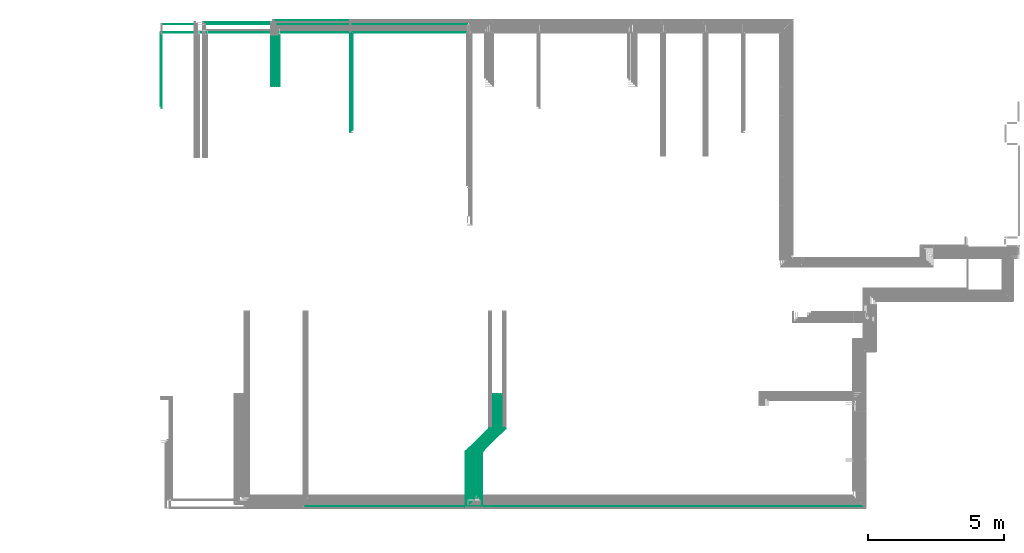
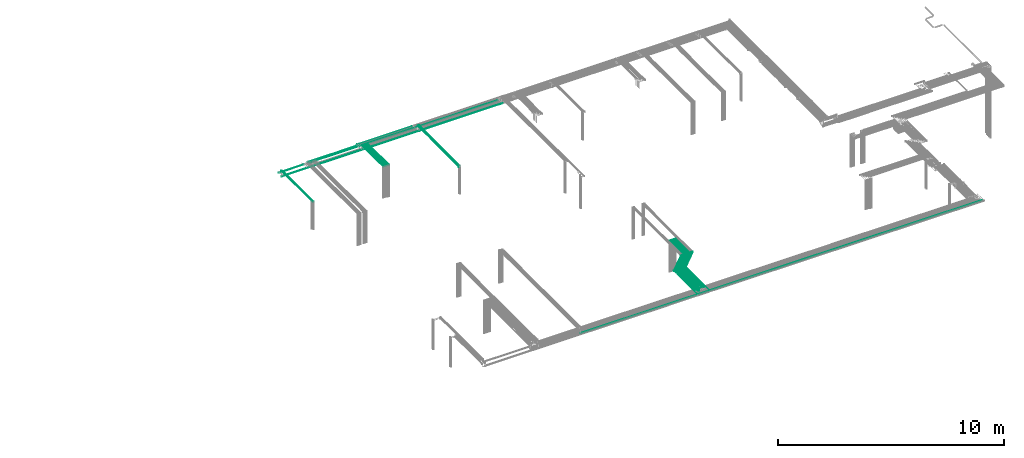
# One storey, part 11 of 89: 40 flow segments.
"""IFC2X3 building model written with IfcOpenShell, lengths in millimetres."""

from ifc_helpers import new_model, entity, si_unit, converted_unit, derived_unit, direction, frame, frame_2d, origin, origin_2d_with_axis, place, context, subcontext, project, spatial, circle, extrude, type_object, element, save


model = new_model("IFC2X3")

# Units and contexts
model_context = context("Model", 3, precision=0.01, world=origin(), true_north=direction((6.12303176911189e-17, 1.0)))
body_context = subcontext(model_context, "Body", "Model", "MODEL_VIEW")
ifc_project = project(units=[si_unit("LENGTHUNIT", "METRE", prefix="MILLI"), si_unit("AREAUNIT", "SQUARE_METRE"), si_unit("VOLUMEUNIT", "CUBIC_METRE"), converted_unit("PLANEANGLEUNIT", "DEGREE", entity("IfcRatioMeasure", 0.0174532925199433), si_unit("PLANEANGLEUNIT", "RADIAN"), dimensions=[0, 0, 0, 0, 0, 0, 0]), si_unit("MASSUNIT", "GRAM", prefix="KILO"), derived_unit("MASSDENSITYUNIT", [(si_unit("MASSUNIT", "GRAM", prefix="KILO"), 1), (si_unit("LENGTHUNIT", "METRE"), -3)]), derived_unit("MOMENTOFINERTIAUNIT", [(si_unit("LENGTHUNIT", "METRE"), 4)]), si_unit("TIMEUNIT", "SECOND"), si_unit("FREQUENCYUNIT", "HERTZ"), si_unit("THERMODYNAMICTEMPERATUREUNIT", "DEGREE_CELSIUS"), derived_unit("THERMALTRANSMITTANCEUNIT", [(si_unit("MASSUNIT", "GRAM", prefix="KILO"), 1), (si_unit("THERMODYNAMICTEMPERATUREUNIT", "KELVIN"), -1), (si_unit("TIMEUNIT", "SECOND"), -3)]), derived_unit("VOLUMETRICFLOWRATEUNIT", [(si_unit("LENGTHUNIT", "METRE"), 3), (si_unit("TIMEUNIT", "SECOND"), -1)]), derived_unit("MASSFLOWRATEUNIT", [(si_unit("MASSUNIT", "GRAM", prefix="KILO"), 1), (si_unit("TIMEUNIT", "SECOND"), -1)]), derived_unit("ROTATIONALFREQUENCYUNIT", [(si_unit("TIMEUNIT", "SECOND"), -1)]), si_unit("ELECTRICCURRENTUNIT", "AMPERE"), si_unit("ELECTRICVOLTAGEUNIT", "VOLT"), si_unit("POWERUNIT", "WATT"), si_unit("FORCEUNIT", "NEWTON", prefix="KILO"), si_unit("ILLUMINANCEUNIT", "LUX"), si_unit("LUMINOUSFLUXUNIT", "LUMEN"), si_unit("LUMINOUSINTENSITYUNIT", "CANDELA"), derived_unit("USERDEFINED", [(si_unit("MASSUNIT", "GRAM", prefix="KILO"), -1), (si_unit("LENGTHUNIT", "METRE"), -2), (si_unit("TIMEUNIT", "SECOND"), 3), (si_unit("LUMINOUSFLUXUNIT", "LUMEN"), 1)]), derived_unit("LINEARVELOCITYUNIT", [(si_unit("LENGTHUNIT", "METRE"), 1), (si_unit("TIMEUNIT", "SECOND"), -1)]), si_unit("PRESSUREUNIT", "PASCAL"), derived_unit("USERDEFINED", [(si_unit("LENGTHUNIT", "METRE"), -2), (si_unit("MASSUNIT", "GRAM", prefix="KILO"), 1), (si_unit("TIMEUNIT", "SECOND"), -2)]), derived_unit("LINEARFORCEUNIT", [(si_unit("MASSUNIT", "GRAM", prefix="KILO"), 1), (si_unit("LENGTHUNIT", "METRE"), 1), (si_unit("TIMEUNIT", "SECOND"), -2), (si_unit("LENGTHUNIT", "METRE"), -1)]), derived_unit("PLANARFORCEUNIT", [(si_unit("MASSUNIT", "GRAM", prefix="KILO"), 1), (si_unit("LENGTHUNIT", "METRE"), 1), (si_unit("TIMEUNIT", "SECOND"), -2), (si_unit("LENGTHUNIT", "METRE"), -2)])], contexts=[model_context])

# Site, building, storey
site_placement = place(None, frame((0.0, -0.00077364408347762, 0.0)))
site = spatial("IfcSite", under=ifc_project, at=site_placement, CompositionType="ELEMENT")
building_placement = place(site_placement, origin())
building = spatial("IfcBuilding", under=site, at=building_placement, CompositionType="ELEMENT")
storey_placement = place(building_placement, frame((0.0, 0.0, 24000.0)))
storey = spatial("IfcBuildingStorey", under=building, at=storey_placement, CompositionType="ELEMENT", Elevation=24000.0)

# Flow segments
pipe_segment_type = type_object("IfcPipeSegmentType", PredefinedType="NOTDEFINED")
flow_segment_1_placement = place(storey_placement, frame((53135.5981151137, 1334.95129953586, 3069.40472776409)))
element("IfcFlowSegment", 1, at=flow_segment_1_placement, inside=storey, type_object=pipe_segment_type, context=body_context, shape_type="SweptSolid", body=[
    extrude(circle(Radius=4.0, at=origin_2d_with_axis()), frame((5.59527223591499, 0.0, 5.59527223591499), z_axis=(0.0, 1.0, 0.0), x_axis=(1.0, 0.0, 0.0)), (0.0, 0.0, 1.0), 1914.32054256963),
])
flow_segment_2_placement = place(storey_placement, frame((53211.0054086232, 1409.95129953583, 3069.40472776409)))
element("IfcFlowSegment", 2, at=flow_segment_2_placement, inside=storey, type_object=pipe_segment_type, context=body_context, shape_type="SweptSolid", body=[
    extrude(circle(Radius=4.0, at=origin_2d_with_axis()), frame((5.59527223590633, 0.0, 5.59527223591499), z_axis=(0.0, 1.0, 0.0), x_axis=(1.0, 0.0, 0.0)), (0.0, 0.0, 1.0), 1839.32054256966),
])
flow_segment_3_placement = place(storey_placement, frame((53285.5981151137, 1484.95129953586, 3069.40472776409)))
element("IfcFlowSegment", 3, at=flow_segment_3_placement, inside=storey, type_object=pipe_segment_type, context=body_context, shape_type="SweptSolid", body=[
    extrude(circle(Radius=4.0, at=origin_2d_with_axis()), frame((5.59527223591499, 0.0, 5.59527223591499), z_axis=(0.0, 1.0, 0.0), x_axis=(1.0, 0.0, 0.0)), (0.0, 0.0, 1.0), 1764.32054256963),
])
flow_segment_4_placement = place(storey_placement, frame((53360.5981151137, 1634.95129953587, 3069.40472776409)))
element("IfcFlowSegment", 4, at=flow_segment_4_placement, inside=storey, type_object=pipe_segment_type, context=body_context, shape_type="SweptSolid", body=[
    extrude(circle(Radius=4.0, at=origin_2d_with_axis()), frame((5.59527223591499, 0.0, 5.59527223591499), z_axis=(0.0, 1.0, 0.0), x_axis=(1.0, 0.0, 0.0)), (0.0, 0.0, 1.0), 1614.32054256962),
])
flow_segment_5_placement = place(storey_placement, frame((53435.5981151137, 1559.95129953584, 3069.40472776409)))
element("IfcFlowSegment", 5, at=flow_segment_5_placement, inside=storey, type_object=pipe_segment_type, context=body_context, shape_type="SweptSolid", body=[
    extrude(circle(Radius=4.0, at=origin_2d_with_axis()), frame((5.59527223590633, 0.0, 5.59527223591499), z_axis=(0.0, 1.0, 0.0), x_axis=(1.0, 0.0, 0.0)), (0.0, 0.0, 1.0), 1689.32054256965),
])
flow_segment_6_placement = place(storey_placement, frame((53510.5981151137, 1484.95129953586, 3069.40472776409)))
element("IfcFlowSegment", 6, at=flow_segment_6_placement, inside=storey, type_object=pipe_segment_type, context=body_context, shape_type="SweptSolid", body=[
    extrude(circle(Radius=4.0, at=origin_2d_with_axis()), frame((5.59527223591499, 0.0, 5.59527223591499), z_axis=(0.0, 1.0, 0.0), x_axis=(1.0, 0.0, 0.0)), (0.0, 0.0, 1.0), 1764.32054256963),
])
flow_segment_7_placement = place(storey_placement, frame((53585.5981151137, 1184.95129953582, 3069.40472776409)))
element("IfcFlowSegment", 7, at=flow_segment_7_placement, inside=storey, type_object=pipe_segment_type, context=body_context, shape_type="SweptSolid", body=[
    extrude(circle(Radius=4.0, at=origin_2d_with_axis()), frame((5.59527223591499, 0.0, 5.59527223591499), z_axis=(0.0, 1.0, 0.0), x_axis=(1.0, 0.0, 0.0)), (0.0, 0.0, 1.0), 2064.32054256967),
])
flow_segment_8_placement = place(storey_placement, frame((53060.5981151137, 1484.95129953586, 3069.40472776409)))
element("IfcFlowSegment", 8, at=flow_segment_8_placement, inside=storey, type_object=pipe_segment_type, context=body_context, shape_type="SweptSolid", body=[
    extrude(circle(Radius=4.0, at=origin_2d_with_axis()), frame((5.59527223590633, 0.0, 5.59527223591499), z_axis=(0.0, 1.0, 0.0), x_axis=(1.0, 0.0, 0.0)), (0.0, 0.0, 1.0), 1764.32054256963),
])
flow_segment_9_placement = place(storey_placement, frame((52985.5981151137, 1184.95129953582, 3069.40472776409)))
element("IfcFlowSegment", 9, at=flow_segment_9_placement, inside=storey, type_object=pipe_segment_type, context=body_context, shape_type="SweptSolid", body=[
    extrude(circle(Radius=4.0, at=frame_2d((1.10044925673919e-39, 3.0320279620355e-11), x_axis=(1.0, 0.0))), frame((5.59527223591499, 0.0, 5.59527223594531), z_axis=(0.0, 1.0, 0.0), x_axis=(-1.0, 0.0, 0.0)), (0.0, 0.0, 1.0), 2065.83581081374),
])
flow_segment_10_placement = place(storey_placement, frame((47031.1935200703, 1244.3560272999, 2994.40472776409)))
element("IfcFlowSegment", 10, at=flow_segment_10_placement, inside=storey, type_object=pipe_segment_type, context=body_context, shape_type="SweptSolid", body=[
    extrude(circle(Radius=4.0, at=frame_2d((-1.89501747627219e-12, 0.0), x_axis=(1.0, 0.0))), frame((0.0, 5.5952722359177, 5.59527223591499), z_axis=(1.0, 0.0, 0.0), x_axis=(0.0, 1.0, 0.0)), (0.0, 0.0, 1.0), 20553.8067484846),
])
for number, where in (
    (11, (53985.5981151137, 4107.27184210549, 3069.40472776409)),
    (12, (54061.0054086232, 4107.27184210549, 3069.40472776409)),
    (13, (54135.5981151137, 4107.27184210549, 3069.40472776409)),
):
    element("IfcFlowSegment", number, at=place(storey_placement, frame(where)), inside=storey, type_object=pipe_segment_type, context=body_context, shape_type="SweptSolid", body=[
        extrude(circle(Radius=4.0, at=origin_2d_with_axis()), frame((5.59527223591499, 0.0, 5.59527223591499), z_axis=(0.0, 1.0, 0.0), x_axis=(-1.0, 0.0, 0.0)), (0.0, 0.0, 1.0), 1252.73249573645),
    ])
flow_segment_11_placement = place(storey_placement, frame((54210.5981151137, 4107.27184210549, 3069.40472776409)))
element("IfcFlowSegment", 14, at=flow_segment_11_placement, inside=storey, type_object=pipe_segment_type, context=body_context, shape_type="SweptSolid", body=[
    extrude(circle(Radius=4.0, at=frame_2d((8.66293703438714e-12, 0.0), x_axis=(1.0, 0.0))), frame((5.59527223592365, 0.0, 5.59527223591499), z_axis=(0.0, 1.0, 0.0), x_axis=(-1.0, 0.0, 0.0)), (0.0, 0.0, 1.0), 1252.73249573645),
])
flow_segment_12_placement = place(storey_placement, frame((54285.5981151137, 4107.27184210549, 3069.40472776409)))
element("IfcFlowSegment", 15, at=flow_segment_12_placement, inside=storey, type_object=pipe_segment_type, context=body_context, shape_type="SweptSolid", body=[
    extrude(circle(Radius=4.0, at=origin_2d_with_axis()), frame((5.59527223591499, 0.0, 5.59527223591499), z_axis=(0.0, 1.0, 0.0), x_axis=(-1.0, 0.0, 0.0)), (0.0, 0.0, 1.0), 1252.73249573645),
])
flow_segment_13_placement = place(storey_placement, frame((52989.5981151137, 3253.19183811364, 3069.40472776409)))
element("IfcFlowSegment", 16, at=flow_segment_13_placement, inside=storey, type_object=pipe_segment_type, context=body_context, shape_type="SweptSolid", body=[
    extrude(circle(Radius=4.0, at=origin_2d_with_axis()), frame((4.42369936066011, 4.42369936066065, 5.59527223591499), z_axis=(0.707106781186546, 0.707106781186549, 0.0), x_axis=(-0.707106781186549, 0.707106781186546, 0.0)), (0.0, 0.0, 1.0), 1194.08152801714),
])
flow_segment_14_placement = place(storey_placement, frame((53064.5981151137, 3251.67656986958, 3069.40472776409)))
element("IfcFlowSegment", 17, at=flow_segment_14_placement, inside=storey, type_object=pipe_segment_type, context=body_context, shape_type="SweptSolid", body=[
    extrude(circle(Radius=4.0, at=origin_2d_with_axis()), frame((4.42369936065145, 4.42369936066065, 5.59527223591499), z_axis=(0.707106781186546, 0.707106781186549, 0.0), x_axis=(-0.707106781186549, 0.707106781186546, 0.0)), (0.0, 0.0, 1.0), 1194.08152801713),
])
for number, where in (
    (18, (53139.5981151137, 3251.67656986958, 3069.40472776409)),
    (19, (53215.0054086232, 3251.67656986958, 3069.40472776409)),
    (20, (53289.5981151137, 3251.67656986958, 3069.40472776409)),
):
    element("IfcFlowSegment", number, at=place(storey_placement, frame(where)), inside=storey, type_object=pipe_segment_type, context=body_context, shape_type="SweptSolid", body=[
        extrude(circle(Radius=4.0, at=origin_2d_with_axis()), frame((4.42369936065145, 4.4236993606612, 5.59527223591499), z_axis=(0.707106781186545, 0.70710678118655, 0.0), x_axis=(-0.70710678118655, 0.707106781186545, 0.0)), (0.0, 0.0, 1.0), 1194.08152801713),
    ])
flow_segment_15_placement = place(storey_placement, frame((53364.5981151137, 3251.67656986958, 3069.40472776409)))
element("IfcFlowSegment", 21, at=flow_segment_15_placement, inside=storey, type_object=pipe_segment_type, context=body_context, shape_type="SweptSolid", body=[
    extrude(circle(Radius=4.0, at=origin_2d_with_axis()), frame((4.42369936065145, 4.42369936066065, 5.59527223591499), z_axis=(0.707106781186546, 0.707106781186549, 0.0), x_axis=(-0.707106781186549, 0.707106781186546, 0.0)), (0.0, 0.0, 1.0), 1194.08152801713),
])
flow_segment_16_placement = place(storey_placement, frame((53439.5981151137, 3251.67656986958, 3069.40472776409)))
element("IfcFlowSegment", 22, at=flow_segment_16_placement, inside=storey, type_object=pipe_segment_type, context=body_context, shape_type="SweptSolid", body=[
    extrude(circle(Radius=4.0, at=origin_2d_with_axis()), frame((4.42369936065145, 4.4236993606612, 5.59527223591499), z_axis=(0.707106781186545, 0.70710678118655, 0.0), x_axis=(-0.70710678118655, 0.707106781186545, 0.0)), (0.0, 0.0, 1.0), 1194.08152801713),
])
for number, where in (
    (23, (53514.5981151137, 3251.67656986958, 3069.40472776409)),
    (24, (53589.5981151137, 3251.67656986958, 3069.40472776409)),
):
    element("IfcFlowSegment", number, at=place(storey_placement, frame(where)), inside=storey, type_object=pipe_segment_type, context=body_context, shape_type="SweptSolid", body=[
        extrude(circle(Radius=4.0, at=origin_2d_with_axis()), frame((4.42369936066011, 4.4236993606612, 5.59527223591499), z_axis=(0.707106781186545, 0.70710678118655, 0.0), x_axis=(-0.70710678118655, 0.707106781186545, 0.0)), (0.0, 0.0, 1.0), 1194.08152801713),
    ])
flow_segment_17_placement = place(storey_placement, frame((41771.3043091155, 15945.0, 3069.4047277641)))
element("IfcFlowSegment", 25, at=flow_segment_17_placement, inside=storey, type_object=pipe_segment_type, context=body_context, shape_type="SweptSolid", body=[
    extrude(circle(Radius=4.0, at=frame_2d((-8.66293703438714e-12, 0.0), x_axis=(1.0, 0.0))), frame((5.59527223591499, 0.0, 5.59527223591499), z_axis=(0.0, 1.0, 0.0), x_axis=(-1.0, 0.0, 0.0)), (0.0, 0.0, 1.0), 2695.00000730896),
])
flow_segment_18_placement = place(storey_placement, frame((41814.4237854135, 15870.0, 3069.4047277641)))
element("IfcFlowSegment", 26, at=flow_segment_18_placement, inside=storey, type_object=pipe_segment_type, context=body_context, shape_type="SweptSolid", body=[
    extrude(circle(Radius=4.0, at=origin_2d_with_axis()), frame((5.59527223590633, 0.0, 5.59527223591499), z_axis=(0.0, 1.0, 0.0), x_axis=(1.0, 0.0, 0.0)), (0.0, 0.0, 1.0), 2700.00000000001),
])
flow_segment_19_placement = place(storey_placement, frame((43415.3360917165, 18944.4047277641, 2769.4047277641)))
element("IfcFlowSegment", 27, at=flow_segment_19_placement, inside=storey, type_object=pipe_segment_type, context=body_context, shape_type="SweptSolid", body=[
    extrude(circle(Radius=4.0, at=origin_2d_with_axis()), frame((0.0, 5.59527223593232, 5.59527223591499), z_axis=(1.0, 0.0, 0.0), x_axis=(0.0, -1.0, 0.0)), (0.0, 0.0, 1.0), 2574.38010976152),
])
flow_segment_20_placement = place(storey_placement, frame((45914.1209292421, 16667.0, 3069.4047277641)))
element("IfcFlowSegment", 28, at=flow_segment_20_placement, inside=storey, type_object=pipe_segment_type, context=body_context, shape_type="SweptSolid", body=[
    extrude(circle(Radius=4.0, at=origin_2d_with_axis()), frame((5.59527223591499, 0.0, 5.59527223591499), z_axis=(0.0, 1.0, 0.0), x_axis=(1.0, 0.0, 0.0)), (0.0, 0.0, 1.0), 1880.00000000001),
])
flow_segment_21_placement = place(storey_placement, frame((45929.716201478, 19094.4047277642, 2769.4047277641)))
element("IfcFlowSegment", 29, at=flow_segment_21_placement, inside=storey, type_object=pipe_segment_type, context=body_context, shape_type="SweptSolid", body=[
    extrude(circle(Radius=4.0, at=frame_2d((2.16573425859679e-12, 0.0), x_axis=(1.0, 0.0))), frame((0.0, 5.59527223591499, 5.59527223591499), z_axis=(1.0, 0.0, 0.0), x_axis=(0.0, 1.0, 0.0)), (0.0, 0.0, 1.0), 2811.65681787896),
])
for number, where in (
    (30, (45839.1209292422, 16667.0, 3069.40472776409)),
    (31, (45989.1209292421, 16667.0, 3069.40472776409)),
    (32, (46064.1209292421, 16667.0, 3069.40472776409)),
    (33, (46139.1209292421, 16667.0, 3069.40472776409)),
):
    element("IfcFlowSegment", number, at=place(storey_placement, frame(where)), inside=storey, type_object=pipe_segment_type, context=body_context, shape_type="SweptSolid", body=[
        extrude(circle(Radius=4.0, at=origin_2d_with_axis()), frame((5.59527223591499, 0.0, 5.59527223591499), z_axis=(0.0, 1.0, 0.0), x_axis=(1.0, 0.0, 0.0)), (0.0, 0.0, 1.0), 1880.00000000001),
    ])
flow_segment_22_placement = place(storey_placement, frame((48815.5947989665, 15059.7000254876, 3069.40472776409)))
element("IfcFlowSegment", 34, at=flow_segment_22_placement, inside=storey, type_object=pipe_segment_type, context=body_context, shape_type="SweptSolid", body=[
    extrude(circle(Radius=4.0, at=origin_2d_with_axis()), frame((5.59527223591499, 0.0, 5.59527223591499), z_axis=(0.0, 1.0, 0.0), x_axis=(-1.0, 0.0, 0.0)), (0.0, 0.0, 1.0), 3580.29997451241),
])
flow_segment_23_placement = place(storey_placement, frame((48740.5947989665, 14984.7000254876, 3069.40472776409)))
element("IfcFlowSegment", 35, at=flow_segment_23_placement, inside=storey, type_object=pipe_segment_type, context=body_context, shape_type="SweptSolid", body=[
    extrude(circle(Radius=4.0, at=origin_2d_with_axis()), frame((5.59527223592365, 0.0, 5.59527223591499), z_axis=(0.0, 1.0, 0.0), x_axis=(1.0, 0.0, 0.0)), (0.0, 0.0, 1.0), 3648.45352740054),
])
flow_segment_24_placement = place(storey_placement, frame((48829.1900712024, 18640.9047277641, 2765.90472776411)))
element("IfcFlowSegment", 36, at=flow_segment_24_placement, inside=storey, type_object=pipe_segment_type, context=body_context, shape_type="SweptSolid", body=[
    extrude(circle(Radius=7.5, at=frame_2d((-2.16573425859679e-12, 0.0), x_axis=(1.0, 0.0))), frame((0.0, 9.09527223591853, 9.09527223591419), z_axis=(1.0, 0.0, 0.0), x_axis=(0.0, 1.0, 0.0)), (0.0, 0.0, 1.0), 4278.7145697067),
])
flow_segment_25_placement = place(storey_placement, frame((41794.8995813515, 18640.9047277641, 2765.90472776409)))
element("IfcFlowSegment", 37, at=flow_segment_25_placement, inside=storey, type_object=pipe_segment_type, context=body_context, shape_type="SweptSolid", body=[
    extrude(circle(Radius=7.5, at=origin_2d_with_axis()), frame((0.0, 9.09527223591853, 9.09527223591419), z_axis=(1.0, 0.0, 0.0), x_axis=(0.0, -1.0, 0.0)), (0.0, 0.0, 1.0), 7018.29048985094),
])
flow_segment_26_placement = place(storey_placement, frame((45999.7162014781, 18944.4047277642, 2769.4047277641)))
element("IfcFlowSegment", 38, at=flow_segment_26_placement, inside=storey, type_object=pipe_segment_type, context=body_context, shape_type="SweptSolid", body=[
    extrude(circle(Radius=4.0, at=frame_2d((2.16573425859679e-12, 0.0), x_axis=(1.0, 0.0))), frame((0.0, 5.59527223591716, 5.59527223591499), z_axis=(1.0, 0.0, 0.0), x_axis=(0.0, 1.0, 0.0)), (0.0, 0.0, 1.0), 7036.09698396919),
])
flow_segment_27_placement = place(storey_placement, frame((41830.0190576494, 18944.4047277642, 2769.40472776408)))
element("IfcFlowSegment", 39, at=flow_segment_27_placement, inside=storey, type_object=pipe_segment_type, context=body_context, shape_type="SweptSolid", body=[
    extrude(circle(Radius=4.0, at=origin_2d_with_axis()), frame((0.0, 5.59527223591499, 5.59527223591499), z_axis=(1.0, 0.0, 0.0), x_axis=(0.0, -1.0, 0.0)), (0.0, 0.0, 1.0), 1275.60243171032),
])
flow_segment_28_placement = place(storey_placement, frame((43340.3360917165, 19019.4047277642, 2769.40472776408)))
element("IfcFlowSegment", 40, at=flow_segment_28_placement, inside=storey, type_object=pipe_segment_type, context=body_context, shape_type="SweptSolid", body=[
    extrude(circle(Radius=4.0, at=origin_2d_with_axis()), frame((0.0, 5.59527223591499, 5.59527223591499), z_axis=(1.0, 0.0, 0.0), x_axis=(0.0, -1.0, 0.0)), (0.0, 0.0, 1.0), 2499.38010976152),
])

save(model, "model.ifc")
